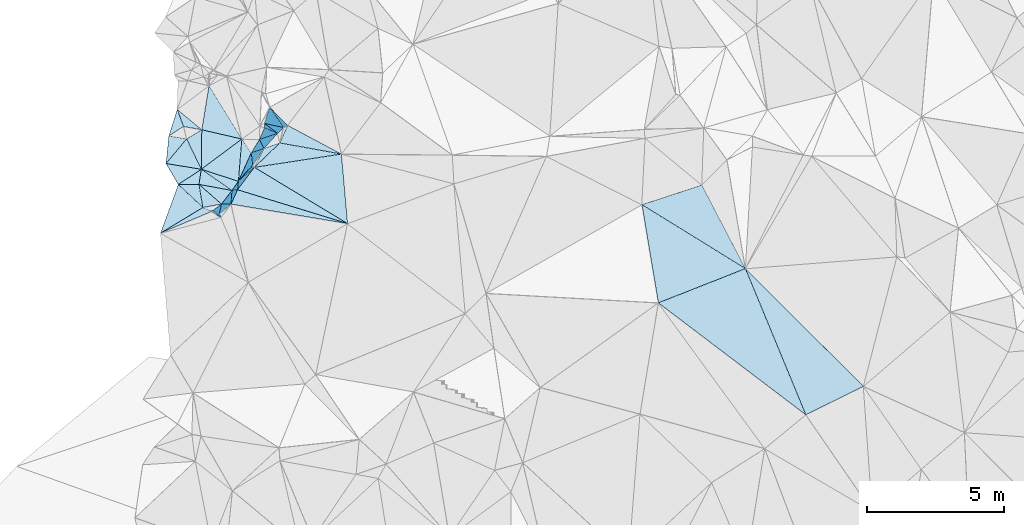
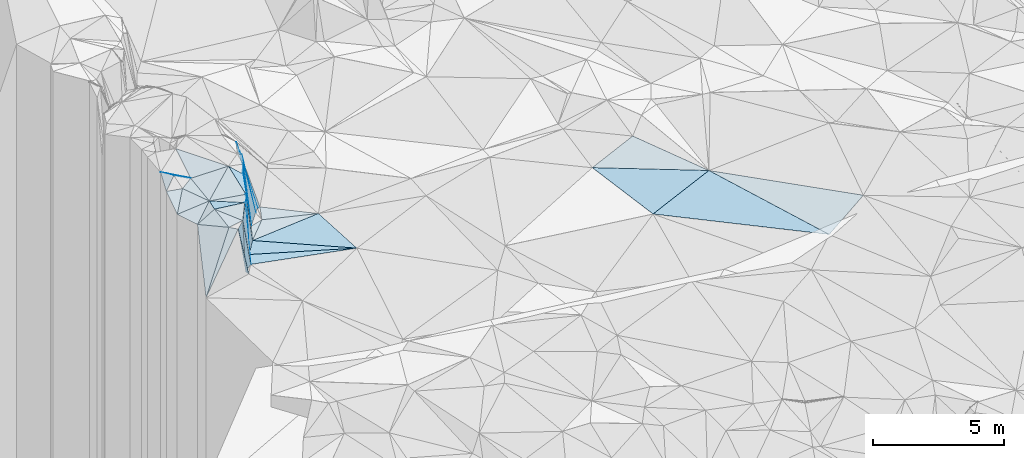
# One storey, part 71 of 275: 45 plates.
"""IFC2X3 building model written with IfcOpenShell, lengths in millimetres."""

from ifc_helpers import new_model, si_unit, frame, origin_with_axes, place, context, subcontext, project, spatial, polyline, outline, extrude, material, type_object, element, save


model = new_model("IFC2X3")

# Units and contexts
model_context = context("Model", 3, precision=1e-05, world=origin_with_axes())
body_context = subcontext(model_context, "Body", "Model", "MODEL_VIEW")
ifc_project = project(units=[si_unit("LENGTHUNIT", "METRE", prefix="MILLI"), si_unit("AREAUNIT", "SQUARE_METRE"), si_unit("VOLUMEUNIT", "CUBIC_METRE"), si_unit("MASSUNIT", "GRAM", prefix="KILO"), si_unit("TIMEUNIT", "SECOND"), si_unit("PLANEANGLEUNIT", "RADIAN"), si_unit("SOLIDANGLEUNIT", "STERADIAN"), si_unit("THERMODYNAMICTEMPERATUREUNIT", "DEGREE_CELSIUS"), si_unit("LUMINOUSINTENSITYUNIT", "LUMEN")], contexts=[model_context])

# Site, building, storey
site_placement = place(None, origin_with_axes())
site = spatial("IfcSite", under=ifc_project, at=site_placement, CompositionType="ELEMENT")
building_placement = place(site_placement, origin_with_axes())
building = spatial("IfcBuilding", under=site, at=building_placement, Name="Undefined", CompositionType="ELEMENT")
storey_placement = place(building_placement, origin_with_axes())
storey = spatial("IfcBuildingStorey", under=building, at=storey_placement, Name="Undefined", CompositionType="ELEMENT", Elevation=0.0)

# Plates
ifc_material = material()
plate_type_1 = type_object("IfcPlateType", PredefinedType="NOTDEFINED")
plate_1_placement = place(storey_placement, frame((-135859.955558861, 84873.9597240166, 56009.9690925926), z_axis=(-0.80113444604956, 0.595285873757035, -0.0617926197712092), x_axis=(0.210717895089525, 0.183923351071946, -0.960088625919246)))
element("IfcPlate", 1, at=plate_1_placement, inside=storey, type_object=plate_type_1, material=ifc_material, Name="00", context=body_context, shape_type="SweptSolid", body=[
    extrude(outline(polyline([(0.0, 0.0), (2770.57763671875, 1.31149135995656e-09), (2433.75244140625, 965.530334472656), (0.0, 0.0)])), frame((-8.85201319254618e-08, 2.18876761149539e-07, -0.5000001331573), z_axis=(0.0, 0.0, 1.0), x_axis=(1.0, 0.0, 0.0)), (0.0, 0.0, 1.0), 1.0),
])
plate_type_2 = type_object("IfcPlateType", PredefinedType="NOTDEFINED")
plate_2_placement = place(storey_placement, frame((-134925.469018545, 86074.3405965202, 53479.9368128959), z_axis=(-0.720463312959929, 0.681885485908866, -0.126351884772781), x_axis=(-0.0607243551866991, 0.119466472984802, 0.990979472299871)))
element("IfcPlate", 2, at=plate_2_placement, inside=storey, type_object=plate_type_2, material=ifc_material, Name="00", context=body_context, shape_type="SweptSolid", body=[
    extrude(outline(polyline([(0.0, 0.0), (2764.94116210938, -5.52245182916522e-09), (144.234527587891, 737.357727050781), (0.0, 0.0)])), frame((-8.85201319254618e-08, 2.18876761149539e-07, -0.5000001331573), z_axis=(0.0, 0.0, 1.0), x_axis=(1.0, 0.0, 0.0)), (0.0, 0.0, 1.0), 1.0),
])
plate_type_3 = type_object("IfcPlateType", PredefinedType="NOTDEFINED")
plate_3_placement = place(storey_placement, frame((-136829.758538089, 83777.7157619968, 55399.9578106558), z_axis=(-0.851247246869995, -0.517940403688101, -0.0843555743484753), x_axis=(0.131245253140648, -0.0544902259312049, -0.989851250848335)))
element("IfcPlate", 3, at=plate_3_placement, inside=storey, type_object=plate_type_3, material=ifc_material, Name="00", context=body_context, shape_type="SweptSolid", body=[
    extrude(outline(polyline([(0.0, 0.0), (2040.71069335938, 1.74622982740402e-10), (2104.51196289063, 115.019104003906), (0.0, 0.0)])), frame((-8.85201319254618e-08, 2.18876761149539e-07, -0.5000001331573), z_axis=(0.0, 0.0, 1.0), x_axis=(1.0, 0.0, 0.0)), (0.0, 0.0, 1.0), 1.0),
])
plate_type_4 = type_object("IfcPlateType", PredefinedType="NOTDEFINED")
plate_4_placement = place(storey_placement, frame((-137213.128174042, 85313.9926482417, 55909.504713862), z_axis=(0.0737227452960772, 0.115900308503078, -0.990521113008148), x_axis=(-0.432701994321931, 0.898581736098414, 0.0729372858021486)))
element("IfcPlate", 4, at=plate_4_placement, inside=storey, type_object=plate_type_4, material=ifc_material, Name="00", context=body_context, shape_type="SweptSolid", body=[
    extrude(outline(polyline([(0.0, 0.0), (1233.93676757813, -8.44011083245277e-10), (1298.76989746094, 646.681274414063), (0.0, 0.0)])), frame((-8.85201319254618e-08, 2.18876761149539e-07, -0.5000001331573), z_axis=(0.0, 0.0, 1.0), x_axis=(1.0, 0.0, 0.0)), (0.0, 0.0, 1.0), 1.0),
])
plate_type_5 = type_object("IfcPlateType", PredefinedType="NOTDEFINED")
plate_5_placement = place(storey_placement, frame((-136127.6554632, 84044.8597834643, 53349.9647469761), z_axis=(-0.903278146051809, 0.423230923628092, -0.0704569098819942), x_axis=(0.0124433267465963, 0.189985869203093, 0.981707967331743)))
element("IfcPlate", 5, at=plate_5_placement, inside=storey, type_object=plate_type_5, material=ifc_material, Name="00", context=body_context, shape_type="SweptSolid", body=[
    extrude(outline(polyline([(0.0, 0.0), (2607.7001953125, -1.10157998278737e-08), (160.946426391602, 554.072448730469), (0.0, 0.0)])), frame((-8.85201319254618e-08, 2.18876761149539e-07, -0.5000001331573), z_axis=(0.0, 0.0, 1.0), x_axis=(1.0, 0.0, 0.0)), (0.0, 0.0, 1.0), 1.0),
])
plate_type_6 = type_object("IfcPlateType", PredefinedType="NOTDEFINED")
plate_6_placement = place(storey_placement, frame((-136476.814629758, 84043.6764697273, 55509.9471118911), z_axis=(-0.656866951895646, 0.746553389265246, -0.105753697258755), x_axis=(0.159631196157511, 0.000614677064232366, -0.987176531014301)))
element("IfcPlate", 6, at=plate_6_placement, inside=storey, type_object=plate_type_6, material=ifc_material, Name="00", context=body_context, shape_type="SweptSolid", body=[
    extrude(outline(polyline([(0.0, 0.0), (2188.05859375, -2.40106601268053e-09), (2088.8837890625, 567.859497070313), (0.0, 0.0)])), frame((-8.85201319254618e-08, 2.18876761149539e-07, -0.5000001331573), z_axis=(0.0, 0.0, 1.0), x_axis=(1.0, 0.0, 0.0)), (0.0, 0.0, 1.0), 1.0),
])
plate_type_7 = type_object("IfcPlateType", PredefinedType="NOTDEFINED")
plate_7_placement = place(storey_placement, frame((-121138.638647464, 84023.4139088825, 52609.5063671634), z_axis=(0.0760480772264629, 0.140023477163712, -0.98722343762349), x_axis=(0.943962889910222, 0.308801539201144, 0.116514685166062)))
element("IfcPlate", 7, at=plate_7_placement, inside=storey, type_object=plate_type_7, material=ifc_material, Name="00", context=body_context, shape_type="SweptSolid", body=[
    extrude(outline(polyline([(0.0, 0.0), (2317.30444335938, -4.46743797510862e-09), (2839.03125, 3411.33422851563), (0.0, 0.0)])), frame((-8.85201319254618e-08, 2.18876761149539e-07, -0.5000001331573), z_axis=(0.0, 0.0, 1.0), x_axis=(1.0, 0.0, 0.0)), (0.0, 0.0, 1.0), 1.0),
])
plate_type_8 = type_object("IfcPlateType", PredefinedType="NOTDEFINED")
plate_8_placement = place(storey_placement, frame((-138049.635422818, 84758.1283392412, 55449.5688934426), z_axis=(0.504498801988477, -0.0459132699492571, -0.86219077380517), x_axis=(0.757346907758172, 0.503058939108735, 0.416362060101456)))
element("IfcPlate", 8, at=plate_8_placement, inside=storey, type_object=plate_type_8, material=ifc_material, Name="00", context=body_context, shape_type="SweptSolid", body=[
    extrude(outline(polyline([(0.0, 0.0), (1104.8076171875, 4.86033968627453e-09), (755.335083007813, 434.935516357422), (0.0, 0.0)])), frame((-8.85201319254618e-08, 2.18876761149539e-07, -0.5000001331573), z_axis=(0.0, 0.0, 1.0), x_axis=(1.0, 0.0, 0.0)), (0.0, 0.0, 1.0), 1.0),
])
plate_type_9 = type_object("IfcPlateType", PredefinedType="NOTDEFINED")
plate_9_placement = place(storey_placement, frame((-138049.754522932, 84758.3234239179, 55449.5498289289), z_axis=(0.266292235218484, 0.344259722706967, -0.900318659577855), x_axis=(-0.496981200272408, 0.849355489909906, 0.177777777958048)))
element("IfcPlate", 9, at=plate_9_placement, inside=storey, type_object=plate_type_9, material=ifc_material, Name="00", context=body_context, shape_type="SweptSolid", body=[
    extrude(outline(polyline([(0.0, 0.0), (900.0, -1.98633642867208e-09), (138.0, 1096.15515136719), (0.0, 0.0)])), frame((-8.85201319254618e-08, 2.18876761149539e-07, -0.5000001331573), z_axis=(0.0, 0.0, 1.0), x_axis=(1.0, 0.0, 0.0)), (0.0, 0.0, 1.0), 1.0),
])
plate_type_10 = type_object("IfcPlateType", PredefinedType="NOTDEFINED")
plate_10_placement = place(storey_placement, frame((-137153.691636111, 83919.0025209846, 55509.6846420428), z_axis=(0.552665008557406, 0.544782422794588, -0.630692873061287), x_axis=(-0.54859898368213, -0.331875836051629, -0.767396627923245)))
element("IfcPlate", 10, at=plate_10_placement, inside=storey, type_object=plate_type_10, material=ifc_material, Name="00", context=body_context, shape_type="SweptSolid", body=[
    extrude(outline(polyline([(0.0, 0.0), (2814.71142578125, 8.73114913702011e-11), (258.960845947266, 1201.5986328125), (0.0, 0.0)])), frame((-8.85201319254618e-08, 2.18876761149539e-07, -0.5000001331573), z_axis=(0.0, 0.0, 1.0), x_axis=(1.0, 0.0, 0.0)), (0.0, 0.0, 1.0), 1.0),
])
plate_type_11 = type_object("IfcPlateType", PredefinedType="NOTDEFINED")
plate_11_placement = place(storey_placement, frame((-135732.742907222, 86416.8519997298, 56339.5205810987), z_axis=(-0.179842258883582, 0.21984046225703, -0.958815380078076), x_axis=(0.539640327145978, -0.792899381766069, -0.283017468918028)))
element("IfcPlate", 11, at=plate_11_placement, inside=storey, type_object=plate_type_11, material=ifc_material, Name="00", context=body_context, shape_type="SweptSolid", body=[
    extrude(outline(polyline([(0.0, 0.0), (636.003173828125, 2.24827090278268e-09), (1248.42150878906, 973.418579101563), (0.0, 0.0)])), frame((-8.85201319254618e-08, 2.18876761149539e-07, -0.5000001331573), z_axis=(0.0, 0.0, 1.0), x_axis=(1.0, 0.0, 0.0)), (0.0, 0.0, 1.0), 1.0),
])
plate_type_12 = type_object("IfcPlateType", PredefinedType="NOTDEFINED")
plate_12_placement = place(storey_placement, frame((-137213.065455217, 85313.9908148479, 55909.5132139041), z_axis=(0.199148502702241, 0.112233871361136, -0.973521151280622), x_axis=(0.0131467967339317, 0.993024645001203, 0.117171737871687)))
element("IfcPlate", 12, at=plate_12_placement, inside=storey, type_object=plate_type_12, material=ifc_material, Name="00", context=body_context, shape_type="SweptSolid", body=[
    extrude(outline(polyline([(0.0, 0.0), (1450.86181640625, 8.13452061265707e-09), (1164.96276855469, 1495.27978515625), (0.0, 0.0)])), frame((-8.85201319254618e-08, 2.18876761149539e-07, -0.5000001331573), z_axis=(0.0, 0.0, 1.0), x_axis=(1.0, 0.0, 0.0)), (0.0, 0.0, 1.0), 1.0),
])
plate_type_13 = type_object("IfcPlateType", PredefinedType="NOTDEFINED")
plate_13_placement = place(storey_placement, frame((-137153.740925375, 83918.9445444771, 55509.6095047194), z_axis=(0.45408710430378, 0.42882823042463, -0.780968149475949), x_axis=(-0.728871930194267, 0.682907770884723, -0.048812763086533)))
element("IfcPlate", 13, at=plate_13_placement, inside=storey, type_object=plate_type_13, material=ifc_material, Name="00", context=body_context, shape_type="SweptSolid", body=[
    extrude(outline(polyline([(0.0, 0.0), (1229.18676757813, -7.17409420758486e-09), (662.470520019531, 662.218078613281), (0.0, 0.0)])), frame((-8.85201319254618e-08, 2.18876761149539e-07, -0.5000001331573), z_axis=(0.0, 0.0, 1.0), x_axis=(1.0, 0.0, 0.0)), (0.0, 0.0, 1.0), 1.0),
])
plate_type_14 = type_object("IfcPlateType", PredefinedType="NOTDEFINED")
plate_14_placement = place(storey_placement, frame((-136476.52288209, 84043.5027052583, 55509.5429879222), z_axis=(-0.0733708197675231, 0.399022001624005, -0.914001184368278), x_axis=(-0.983511645452733, -0.180844804345762, -1.48331007963855e-10)))
element("IfcPlate", 14, at=plate_14_placement, inside=storey, type_object=plate_type_14, material=ifc_material, Name="00", context=body_context, shape_type="SweptSolid", body=[
    extrude(outline(polyline([(0.0, 0.0), (688.839599609375, 5.10772224515677e-09), (677.371032714844, 936.626098632813), (0.0, 0.0)])), frame((-8.85201319254618e-08, 2.18876761149539e-07, -0.5000001331573), z_axis=(0.0, 0.0, 1.0), x_axis=(1.0, 0.0, 0.0)), (0.0, 0.0, 1.0), 1.0),
])
plate_15_placement = place(storey_placement, frame((-131876.34729675, 83332.7339163438, 53049.5051517594), z_axis=(-0.0471407407113396, 0.135544316976173, -0.989649174556645), x_axis=(-0.983881409658604, 0.164790786734579, 0.0694360737340209)))
element("IfcPlate", 15, at=plate_15_placement, inside=storey, type_object=plate_type_14, material=ifc_material, Name="00", context=body_context, shape_type="SweptSolid", body=[
    extrude(outline(polyline([(0.0, 0.0), (4320.52099609375, -4.93528204970062e-08), (4174.84375, 558.281494140625), (0.0, 0.0)])), frame((-8.85201319254618e-08, 2.18876761149539e-07, -0.5000001331573), z_axis=(0.0, 0.0, 1.0), x_axis=(1.0, 0.0, 0.0)), (0.0, 0.0, 1.0), 1.0),
])
plate_type_15 = type_object("IfcPlateType", PredefinedType="NOTDEFINED")
plate_16_placement = place(storey_placement, frame((-138497.160573646, 85522.7628120226, 55609.5382334081), z_axis=(0.0204090116661482, 0.383099450040495, -0.923481609790624), x_axis=(0.0926083867239027, 0.918978575168784, 0.383278051927249)))
element("IfcPlate", 16, at=plate_16_placement, inside=storey, type_object=plate_type_15, material=ifc_material, Name="00", context=body_context, shape_type="SweptSolid", body=[
    extrude(outline(polyline([(0.0, 0.0), (1095.81018066406, 4.97675500810146e-09), (1046.16662597656, 656.152038574219), (0.0, 0.0)])), frame((-8.85201319254618e-08, 2.18876761149539e-07, -0.5000001331573), z_axis=(0.0, 0.0, 1.0), x_axis=(1.0, 0.0, 0.0)), (0.0, 0.0, 1.0), 1.0),
])
plate_type_16 = type_object("IfcPlateType", PredefinedType="NOTDEFINED")
plate_17_placement = place(storey_placement, frame((-135334.879721302, 85466.8931062696, 53389.9462882037), z_axis=(-0.816999879381124, 0.566547528495554, -0.107401559796912), x_axis=(-0.0195884181771548, 0.158879409902703, 0.987103655642246)))
element("IfcPlate", 17, at=plate_17_placement, inside=storey, type_object=plate_type_16, material=ifc_material, Name="00", context=body_context, shape_type="SweptSolid", body=[
    extrude(outline(polyline([(0.0, 0.0), (2806.18969726563, 1.8007995095104e-10), (177.322296142578, 716.349609375), (0.0, 0.0)])), frame((-8.85201319254618e-08, 2.18876761149539e-07, -0.5000001331573), z_axis=(0.0, 0.0, 1.0), x_axis=(1.0, 0.0, 0.0)), (0.0, 0.0, 1.0), 1.0),
])
plate_type_17 = type_object("IfcPlateType", PredefinedType="NOTDEFINED")
plate_18_placement = place(storey_placement, frame((-117363.102788552, 81690.8126194598, 52569.5009567201), z_axis=(0.0246737993664144, 0.0570532409313664, -0.998066195862806), x_axis=(-0.929526602919656, -0.366131543166801, -0.0439088551768533)))
element("IfcPlate", 18, at=plate_18_placement, inside=storey, type_object=plate_type_17, material=ifc_material, Name="00", context=body_context, shape_type="SweptSolid", body=[
    extrude(outline(polyline([(0.0, 0.0), (3416.16748046875, -1.27911334857345e-08), (2653.70483398438, 3557.40795898438), (0.0, 0.0)])), frame((-8.85201319254618e-08, 2.18876761149539e-07, -0.5000001331573), z_axis=(0.0, 0.0, 1.0), x_axis=(1.0, 0.0, 0.0)), (0.0, 0.0, 1.0), 1.0),
])
plate_type_18 = type_object("IfcPlateType", PredefinedType="NOTDEFINED")
plate_19_placement = place(storey_placement, frame((-134347.018733055, 86275.0128573065, 53449.5103317095), z_axis=(-0.0749880784686422, 0.187934155128248, -0.979314832637499), x_axis=(0.978167482643119, -0.17701847570442, -0.108870726822722)))
element("IfcPlate", 19, at=plate_19_placement, inside=storey, type_object=plate_type_18, material=ifc_material, Name="00", context=body_context, shape_type="SweptSolid", body=[
    extrude(outline(polyline([(0.0, 0.0), (2296.30126953125, 2.56695784628391e-08), (-739.754821777344, 1058.51916503906), (0.0, 0.0)])), frame((-8.85201319254618e-08, 2.18876761149539e-07, -0.5000001331573), z_axis=(0.0, 0.0, 1.0), x_axis=(1.0, 0.0, 0.0)), (0.0, 0.0, 1.0), 1.0),
])
plate_type_19 = type_object("IfcPlateType", PredefinedType="NOTDEFINED")
plate_20_placement = place(storey_placement, frame((-134715.275349319, 87577.7234398187, 56379.8469950898), z_axis=(-0.49808955149146, 0.811343768201269, -0.30598707243281), x_axis=(0.22010078916499, -0.22302229788634, -0.94964029887871)))
element("IfcPlate", 20, at=plate_20_placement, inside=storey, type_object=plate_type_19, material=ifc_material, Name="00", context=body_context, shape_type="SweptSolid", body=[
    extrude(outline(polyline([(0.0, 0.0), (2969.54541015625, -2.06637196242809e-09), (2915.59765625, 166.402069091797), (0.0, 0.0)])), frame((-8.85201319254618e-08, 2.18876761149539e-07, -0.5000001331573), z_axis=(0.0, 0.0, 1.0), x_axis=(1.0, 0.0, 0.0)), (0.0, 0.0, 1.0), 1.0),
])
plate_type_20 = type_object("IfcPlateType", PredefinedType="NOTDEFINED")
plate_21_placement = place(storey_placement, frame((-113058.281381887, 77394.5930506699, 52519.5107019055), z_axis=(0.139621027334878, 0.151285896092549, -0.978579862029374), x_axis=(-0.879703077589457, -0.434719960034995, -0.192720138093587)))
element("IfcPlate", 21, at=plate_21_placement, inside=storey, type_object=plate_type_20, material=ifc_material, Name="00", context=body_context, shape_type="SweptSolid", body=[
    extrude(outline(polyline([(0.0, 0.0), (2386.880859375, 3.55066731572151e-09), (1909.60522460938, 5774.49658203125), (0.0, 0.0)])), frame((-8.85201319254618e-08, 2.18876761149539e-07, -0.5000001331573), z_axis=(0.0, 0.0, 1.0), x_axis=(1.0, 0.0, 0.0)), (0.0, 0.0, 1.0), 1.0),
])
plate_type_21 = type_object("IfcPlateType", PredefinedType="NOTDEFINED")
plate_22_placement = place(storey_placement, frame((-134213.32455319, 86837.3162525758, 53599.8752864557), z_axis=(-0.915522496887582, 0.315619276479762, -0.249405352803663), x_axis=(-0.245598651222573, 0.0524712339099499, 0.967950449211952)))
element("IfcPlate", 22, at=plate_22_placement, inside=storey, type_object=plate_type_21, material=ifc_material, Name="00", context=body_context, shape_type="SweptSolid", body=[
    extrude(outline(polyline([(0.0, 0.0), (2851.3857421875, 6.83940015733242e-09), (2853.06909179688, 623.215209960938), (0.0, 0.0)])), frame((-8.85201319254618e-08, 2.18876761149539e-07, -0.5000001331573), z_axis=(0.0, 0.0, 1.0), x_axis=(1.0, 0.0, 0.0)), (0.0, 0.0, 1.0), 1.0),
])
plate_type_22 = type_object("IfcPlateType", PredefinedType="NOTDEFINED")
plate_23_placement = place(storey_placement, frame((-134424.918909083, 86623.5538702534, 53589.9063553064), z_axis=(-0.879828787628988, 0.436843265864231, -0.1872678977518), x_axis=(-0.245560465087067, -0.0804485080856922, 0.966037315807733)))
element("IfcPlate", 23, at=plate_23_placement, inside=storey, type_object=plate_type_22, material=ifc_material, Name="00", context=body_context, shape_type="SweptSolid", body=[
    extrude(outline(polyline([(0.0, 0.0), (2722.46215820313, -5.13318809680641e-09), (2749.27612304688, 472.314514160156), (0.0, 0.0)])), frame((-8.85201319254618e-08, 2.18876761149539e-07, -0.5000001331573), z_axis=(0.0, 0.0, 1.0), x_axis=(1.0, 0.0, 0.0)), (0.0, 0.0, 1.0), 1.0),
])
plate_type_23 = type_object("IfcPlateType", PredefinedType="NOTDEFINED")
plate_24_placement = place(storey_placement, frame((-134913.655676821, 86986.7726559718, 56359.9133128809), z_axis=(-0.984855198467347, -0.00301680146266575, -0.173352637593944), x_axis=(0.172304934246751, -0.128144672969283, -0.976672899400725)))
element("IfcPlate", 24, at=plate_24_placement, inside=storey, type_object=plate_type_23, material=ifc_material, Name="00", context=body_context, shape_type="SweptSolid", body=[
    extrude(outline(polyline([(0.0, 0.0), (2836.15942382813, -5.2241375669837e-09), (50.9844398498535, 156.206878662109), (0.0, 0.0)])), frame((-8.85201319254618e-08, 2.18876761149539e-07, -0.5000001331573), z_axis=(0.0, 0.0, 1.0), x_axis=(1.0, 0.0, 0.0)), (0.0, 0.0, 1.0), 1.0),
])
plate_type_24 = type_object("IfcPlateType", PredefinedType="NOTDEFINED")
plate_25_placement = place(storey_placement, frame((-138089.934992498, 87495.6068669223, 56219.5784456549), z_axis=(0.53776211622741, -0.00423626607990255, -0.84308597450101), x_axis=(0.339643774164517, -0.914164723944213, 0.22123508801111)))
element("IfcPlate", 25, at=plate_25_placement, inside=storey, type_object=plate_type_24, material=ifc_material, Name="00", context=body_context, shape_type="SweptSolid", body=[
    extrude(outline(polyline([(0.0, 0.0), (678.011779785156, 3.65253072232008e-09), (737.302795410156, 720.405822753906), (0.0, 0.0)])), frame((-8.85201319254618e-08, 2.18876761149539e-07, -0.5000001331573), z_axis=(0.0, 0.0, 1.0), x_axis=(1.0, 0.0, 0.0)), (0.0, 0.0, 1.0), 1.0),
])
plate_type_25 = type_object("IfcPlateType", PredefinedType="NOTDEFINED")
plate_26_placement = place(storey_placement, frame((-135389.89153395, 85912.6660926358, 56159.9571459296), z_axis=(-0.902990769130573, 0.42102917843433, -0.085686065214181), x_axis=(0.0195884181697705, -0.158879409902455, -0.987103655642433)))
element("IfcPlate", 26, at=plate_26_placement, inside=storey, type_object=plate_type_25, material=ifc_material, Name="00", context=body_context, shape_type="SweptSolid", body=[
    extrude(outline(polyline([(0.0, 0.0), (2806.18969726563, 1.8007995095104e-10), (303.899627685547, 1109.1640625), (0.0, 0.0)])), frame((-8.85201319254618e-08, 2.18876761149539e-07, -0.5000001331573), z_axis=(0.0, 0.0, 1.0), x_axis=(1.0, 0.0, 0.0)), (0.0, 0.0, 1.0), 1.0),
])
plate_type_26 = type_object("IfcPlateType", PredefinedType="NOTDEFINED")
plate_27_placement = place(storey_placement, frame((-135389.862319314, 85912.7170786135, 56159.9425875615), z_axis=(-0.844565169207767, 0.5230010484734, -0.114802344300019), x_axis=(0.513383911743619, 0.851844539015881, 0.103912658091505)))
element("IfcPlate", 27, at=plate_27_placement, inside=storey, type_object=plate_type_26, material=ifc_material, Name="00", context=body_context, shape_type="SweptSolid", body=[
    extrude(outline(polyline([(0.0, 0.0), (577.408020019531, -3.63797880709171e-09), (97.5047073364258, 2722.97509765625), (0.0, 0.0)])), frame((-8.85201319254618e-08, 2.18876761149539e-07, -0.5000001331573), z_axis=(0.0, 0.0, 1.0), x_axis=(1.0, 0.0, 0.0)), (0.0, 0.0, 1.0), 1.0),
])
plate_type_27 = type_object("IfcPlateType", PredefinedType="NOTDEFINED")
plate_28_placement = place(storey_placement, frame((-135334.892839461, 85466.3785102252, 53389.8631389316), z_axis=(-0.843237321250245, -0.462643685012076, -0.273699910064214), x_axis=(0.536097171267225, -0.761095584931251, -0.365148371976977)))
element("IfcPlate", 28, at=plate_28_placement, inside=storey, type_object=plate_type_27, material=ifc_material, Name="00", context=body_context, shape_type="SweptSolid", body=[
    extrude(outline(polyline([(0.0, 0.0), (109.544509887695, 6.03904481977224e-10), (-786.894714355469, 2621.54467773438), (0.0, 0.0)])), frame((-8.85201319254618e-08, 2.18876761149539e-07, -0.5000001331573), z_axis=(0.0, 0.0, 1.0), x_axis=(1.0, 0.0, 0.0)), (0.0, 0.0, 1.0), 1.0),
])
plate_type_28 = type_object("IfcPlateType", PredefinedType="NOTDEFINED")
plate_29_placement = place(storey_placement, frame((-136094.687639088, 84540.1721643316, 55909.5143523213), z_axis=(0.13540433267208, 0.19569100835838, -0.971272719652575), x_axis=(-0.822337809986806, 0.568999583713471, -1.02850370525659e-10)))
element("IfcPlate", 29, at=plate_29_placement, inside=storey, type_object=plate_type_28, material=ifc_material, Name="00", context=body_context, shape_type="SweptSolid", body=[
    extrude(outline(polyline([(0.0, 0.0), (1360.03674316406, 9.34232957661152e-09), (-3.60284376144409, 420.222595214844), (0.0, 0.0)])), frame((-8.85201319254618e-08, 2.18876761149539e-07, -0.5000001331573), z_axis=(0.0, 0.0, 1.0), x_axis=(1.0, 0.0, 0.0)), (0.0, 0.0, 1.0), 1.0),
])
plate_type_29 = type_object("IfcPlateType", PredefinedType="NOTDEFINED")
plate_30_placement = place(storey_placement, frame((-135887.618758432, 84566.0640883192, 53409.5020665331), z_axis=(-0.0909250308519354, -0.00504199788368866, -0.995844976400401), x_axis=(0.598309918062655, 0.799113616452505, -0.0586742698979614)))
element("IfcPlate", 30, at=plate_30_placement, inside=storey, type_object=plate_type_29, material=ifc_material, Name="00", context=body_context, shape_type="SweptSolid", body=[
    extrude(outline(polyline([(0.0, 0.0), (1022.5947265625, -5.79166226089001e-09), (1435.46606445313, 3959.85327148438), (0.0, 0.0)])), frame((-8.85201319254618e-08, 2.18876761149539e-07, -0.5000001331573), z_axis=(0.0, 0.0, 1.0), x_axis=(1.0, 0.0, 0.0)), (0.0, 0.0, 1.0), 1.0),
])
plate_type_30 = type_object("IfcPlateType", PredefinedType="NOTDEFINED")
plate_31_placement = place(storey_placement, frame((-135887.976843638, 84566.3602483182, 53409.9695986767), z_axis=(-0.807100604558437, 0.587277025373678, -0.0607808324198443), x_axis=(-0.082585262138582, -0.0103608400568987, 0.99653014378433)))
element("IfcPlate", 31, at=plate_31_placement, inside=storey, type_object=plate_type_30, material=ifc_material, Name="00", context=body_context, shape_type="SweptSolid", body=[
    extrude(outline(polyline([(0.0, 0.0), (2508.70483398438, 3.17959347739816e-09), (2585.4775390625, 413.165771484375), (0.0, 0.0)])), frame((-8.85201319254618e-08, 2.18876761149539e-07, -0.5000001331573), z_axis=(0.0, 0.0, 1.0), x_axis=(1.0, 0.0, 0.0)), (0.0, 0.0, 1.0), 1.0),
])
plate_32_placement = place(storey_placement, frame((-137194.304254801, 86754.4965307773, 56079.5850485535), z_axis=(-0.426816938372086, -0.359407829821876, -0.829851380056338), x_axis=(-0.904323946450534, 0.164501585893941, 0.39387488891082)))
element("IfcPlate", 32, at=plate_32_placement, inside=storey, type_object=plate_type_30, material=ifc_material, Name="00", context=body_context, shape_type="SweptSolid", body=[
    extrude(outline(polyline([(0.0, 0.0), (736.2744140625, 7.63247953727841e-09), (987.403625488281, 629.788940429688), (0.0, 0.0)])), frame((-8.85201319254618e-08, 2.18876761149539e-07, -0.5000001331573), z_axis=(0.0, 0.0, 1.0), x_axis=(1.0, 0.0, 0.0)), (0.0, 0.0, 1.0), 1.0),
])
plate_type_31 = type_object("IfcPlateType", PredefinedType="NOTDEFINED")
plate_33_placement = place(storey_placement, frame((-136095.124676048, 84540.4060509255, 55909.9404714602), z_axis=(-0.738678103962844, 0.663464694840394, -0.119034690011778), x_axis=(-0.0124433268098662, -0.189985869047837, -0.981707967360987)))
element("IfcPlate", 33, at=plate_33_placement, inside=storey, type_object=plate_type_31, material=ifc_material, Name="00", context=body_context, shape_type="SweptSolid", body=[
    extrude(outline(polyline([(0.0, 0.0), (2607.7001953125, -1.10157998278737e-08), (491.812683105469, 557.333190917969), (0.0, 0.0)])), frame((-8.85201319254618e-08, 2.18876761149539e-07, -0.5000001331573), z_axis=(0.0, 0.0, 1.0), x_axis=(1.0, 0.0, 0.0)), (0.0, 0.0, 1.0), 1.0),
])
plate_type_32 = type_object("IfcPlateType", PredefinedType="NOTDEFINED")
plate_34_placement = place(storey_placement, frame((-137297.494308256, 84762.7826210107, 55889.5003857693), z_axis=(0.02268578694698, 0.0327862812033135, -0.999204891318819), x_axis=(0.151163668692774, 0.987858598750767, 0.0358459780381656)))
element("IfcPlate", 34, at=plate_34_placement, inside=storey, type_object=plate_type_32, material=ifc_material, Name="00", context=body_context, shape_type="SweptSolid", body=[
    extrude(outline(polyline([(0.0, 0.0), (557.942626953125, 1.13504938781261e-09), (-37.4590454101563, 1222.78234863281), (0.0, 0.0)])), frame((-8.85201319254618e-08, 2.18876761149539e-07, -0.5000001331573), z_axis=(0.0, 0.0, 1.0), x_axis=(1.0, 0.0, 0.0)), (0.0, 0.0, 1.0), 1.0),
])
plate_type_33 = type_object("IfcPlateType", PredefinedType="NOTDEFINED")
plate_35_placement = place(storey_placement, frame((-136829.235637031, 83778.3957199788, 55399.7483818515), z_axis=(0.194554750172713, 0.841976685088343, -0.50321338510902), x_axis=(-0.647716523481966, -0.274983727996364, -0.710526040723109)))
element("IfcPlate", 35, at=plate_35_placement, inside=storey, type_object=plate_type_33, material=ifc_material, Name="00", context=body_context, shape_type="SweptSolid", body=[
    extrude(outline(polyline([(0.0, 0.0), (2885.18627929688, -1.5192199498415e-08), (93.4081802368164, 358.573425292969), (0.0, 0.0)])), frame((-8.85201319254618e-08, 2.18876761149539e-07, -0.5000001331573), z_axis=(0.0, 0.0, 1.0), x_axis=(1.0, 0.0, 0.0)), (0.0, 0.0, 1.0), 1.0),
])
plate_type_34 = type_object("IfcPlateType", PredefinedType="NOTDEFINED")
plate_36_placement = place(storey_placement, frame((-135732.548856359, 86416.8212469868, 56339.517389633), z_axis=(0.208310609255549, 0.158281538640663, -0.965170267153483), x_axis=(-0.959977608599203, 0.221979471648051, -0.170786724176696)))
element("IfcPlate", 36, at=plate_36_placement, inside=storey, type_object=plate_type_34, material=ifc_material, Name="00", context=body_context, shape_type="SweptSolid", body=[
    extrude(outline(polyline([(0.0, 0.0), (1522.36657714844, -5.79166226089001e-09), (1570.18688964844, 1655.84216308594), (0.0, 0.0)])), frame((-8.85201319254618e-08, 2.18876761149539e-07, -0.5000001331573), z_axis=(0.0, 0.0, 1.0), x_axis=(1.0, 0.0, 0.0)), (0.0, 0.0, 1.0), 1.0),
])
plate_type_35 = type_object("IfcPlateType", PredefinedType="NOTDEFINED")
plate_37_placement = place(storey_placement, frame((-136094.696157792, 84540.3573151009, 55909.5920533619), z_axis=(0.118360861761603, 0.565988771647062, -0.815872181639073), x_axis=(-0.513559926867085, -0.668328842215602, -0.538138235195222)))
element("IfcPlate", 37, at=plate_37_placement, inside=storey, type_object=plate_type_35, material=ifc_material, Name="00", context=body_context, shape_type="SweptSolid", body=[
    extrude(outline(polyline([(0.0, 0.0), (743.303466796875, 4.68571670353413e-09), (479.615692138672, 1125.41943359375), (0.0, 0.0)])), frame((-8.85201319254618e-08, 2.18876761149539e-07, -0.5000001331573), z_axis=(0.0, 0.0, 1.0), x_axis=(1.0, 0.0, 0.0)), (0.0, 0.0, 1.0), 1.0),
])
plate_type_36 = type_object("IfcPlateType", PredefinedType="NOTDEFINED")
plate_38_placement = place(storey_placement, frame((-136561.785592713, 83667.1815218069, 53379.9396969224), z_axis=(-0.572345101621562, 0.811105189402958, -0.120538194666237), x_axis=(-0.131245253214723, 0.0544902258714344, 0.989851250841804)))
element("IfcPlate", 38, at=plate_38_placement, inside=storey, type_object=plate_type_36, material=ifc_material, Name="00", context=body_context, shape_type="SweptSolid", body=[
    extrude(outline(polyline([(0.0, 0.0), (2040.71069335938, 1.74622982740402e-10), (2117.74267578125, 448.403930664063), (0.0, 0.0)])), frame((-8.85201319254618e-08, 2.18876761149539e-07, -0.5000001331573), z_axis=(0.0, 0.0, 1.0), x_axis=(1.0, 0.0, 0.0)), (0.0, 0.0, 1.0), 1.0),
])
plate_type_37 = type_object("IfcPlateType", PredefinedType="NOTDEFINED")
plate_39_placement = place(storey_placement, frame((-134061.463306044, 86915.1430744143, 53559.511445143), z_axis=(-0.0725090798825356, 0.200245198959733, -0.97705900212227), x_axis=(0.870824732080418, -0.464862466752496, -0.159897382723589)))
element("IfcPlate", 39, at=plate_39_placement, inside=storey, type_object=plate_type_37, material=ifc_material, Name="00", context=body_context, shape_type="SweptSolid", body=[
    extrude(outline(polyline([(0.0, 0.0), (2251.44409179688, 2.36068444792181e-08), (66.4906616210938, 706.384460449219), (0.0, 0.0)])), frame((-8.85201319254618e-08, 2.18876761149539e-07, -0.5000001331573), z_axis=(0.0, 0.0, 1.0), x_axis=(1.0, 0.0, 0.0)), (0.0, 0.0, 1.0), 1.0),
])
plate_type_38 = type_object("IfcPlateType", PredefinedType="NOTDEFINED")
plate_40_placement = place(storey_placement, frame((-135275.813015827, 85383.360875307, 53349.5206525972), z_axis=(-0.136531554627681, 0.249718808018107, -0.958644695136297), x_axis=(0.446389365011274, 0.879400895633093, 0.165501056082871)))
element("IfcPlate", 40, at=plate_40_placement, inside=storey, type_object=plate_type_38, material=ifc_material, Name="00", context=body_context, shape_type="SweptSolid", body=[
    extrude(outline(polyline([(0.0, 0.0), (785.493469238281, -6.28642737865448e-09), (1215.28698730469, 436.780883789063), (0.0, 0.0)])), frame((-8.85201319254618e-08, 2.18876761149539e-07, -0.5000001331573), z_axis=(0.0, 0.0, 1.0), x_axis=(1.0, 0.0, 0.0)), (0.0, 0.0, 1.0), 1.0),
])
plate_type_39 = type_object("IfcPlateType", PredefinedType="NOTDEFINED")
plate_41_placement = place(storey_placement, frame((-115158.093495288, 76356.9419680503, 52059.5024319606), z_axis=(0.00819474459295049, 0.0985341616681275, -0.995099927216064), x_axis=(-0.795461340943762, 0.603662575703441, 0.0532235827339794)))
element("IfcPlate", 41, at=plate_41_placement, inside=storey, type_object=plate_type_39, material=ifc_material, Name="00", context=body_context, shape_type="SweptSolid", body=[
    extrude(outline(polyline([(0.0, 0.0), (6763.9189453125, 4.28899511462078e-08), (5001.02099609375, 2926.15625), (0.0, 0.0)])), frame((-8.85201319254618e-08, 2.18876761149539e-07, -0.5000001331573), z_axis=(0.0, 0.0, 1.0), x_axis=(1.0, 0.0, 0.0)), (0.0, 0.0, 1.0), 1.0),
])
plate_type_40 = type_object("IfcPlateType", PredefinedType="NOTDEFINED")
plate_42_placement = place(storey_placement, frame((-137746.965183902, 86422.8272162671, 55999.52664287), z_axis=(0.253502802247944, 0.198911440546371, -0.946662858715925), x_axis=(0.432701994325743, -0.898581736097309, -0.0729372857931509)))
element("IfcPlate", 42, at=plate_42_placement, inside=storey, type_object=plate_type_40, material=ifc_material, Name="00", context=body_context, shape_type="SweptSolid", body=[
    extrude(outline(polyline([(0.0, 0.0), (1233.93676757813, -8.44011083245277e-10), (512.749145507813, 1123.42700195313), (0.0, 0.0)])), frame((-8.85201319254618e-08, 2.18876761149539e-07, -0.5000001331573), z_axis=(0.0, 0.0, 1.0), x_axis=(1.0, 0.0, 0.0)), (0.0, 0.0, 1.0), 1.0),
])
plate_type_41 = type_object("IfcPlateType", PredefinedType="NOTDEFINED")
plate_43_placement = place(storey_placement, frame((-135275.772425462, 85383.2630523291, 53349.5014744459), z_axis=(-0.0553671539311837, 0.054074696385455, -0.9970007048525), x_axis=(0.987447243352389, 0.150902373265261, -0.0466520668210885)))
element("IfcPlate", 43, at=plate_43_placement, inside=storey, type_object=plate_type_41, material=ifc_material, Name="00", context=body_context, shape_type="SweptSolid", body=[
    extrude(outline(polyline([(0.0, 0.0), (3215.29150390625, 2.28901626542211e-08), (3061.30859375, 2545.44482421875), (0.0, 0.0)])), frame((-8.85201319254618e-08, 2.18876761149539e-07, -0.5000001331573), z_axis=(0.0, 0.0, 1.0), x_axis=(1.0, 0.0, 0.0)), (0.0, 0.0, 1.0), 1.0),
])
plate_type_42 = type_object("IfcPlateType", PredefinedType="NOTDEFINED")
plate_44_placement = place(storey_placement, frame((-135859.48720021, 84873.760364972, 56009.5144392154), z_axis=(0.135657416305181, 0.196514920283952, -0.971071033193347), x_axis=(-0.948623772525438, 0.308547545920966, -0.0700810252904098)))
element("IfcPlate", 44, at=plate_44_placement, inside=storey, type_object=plate_type_42, material=ifc_material, Name="00", context=body_context, shape_type="SweptSolid", body=[
    extrude(outline(polyline([(0.0, 0.0), (1426.91979980469, -1.04555510915816e-08), (332.604553222656, 1547.73193359375), (0.0, 0.0)])), frame((-8.85201319254618e-08, 2.18876761149539e-07, -0.5000001331573), z_axis=(0.0, 0.0, 1.0), x_axis=(1.0, 0.0, 0.0)), (0.0, 0.0, 1.0), 1.0),
])
plate_type_43 = type_object("IfcPlateType", PredefinedType="NOTDEFINED")
plate_45_placement = place(storey_placement, frame((-134913.508066305, 86987.1203715822, 56359.8937285742), z_axis=(-0.689552797454334, 0.692361067682564, -0.212492568059126), x_axis=(0.245598651297684, -0.0524712340763681, -0.967950449183873)))
element("IfcPlate", 45, at=plate_45_placement, inside=storey, type_object=plate_type_43, material=ifc_material, Name="00", context=body_context, shape_type="SweptSolid", body=[
    extrude(outline(polyline([(0.0, 0.0), (2851.3857421875, 6.83940015733242e-09), (2820.31298828125, 299.390197753906), (0.0, 0.0)])), frame((-8.85201319254618e-08, 2.18876761149539e-07, -0.5000001331573), z_axis=(0.0, 0.0, 1.0), x_axis=(1.0, 0.0, 0.0)), (0.0, 0.0, 1.0), 1.0),
])

save(model, "model.ifc")
